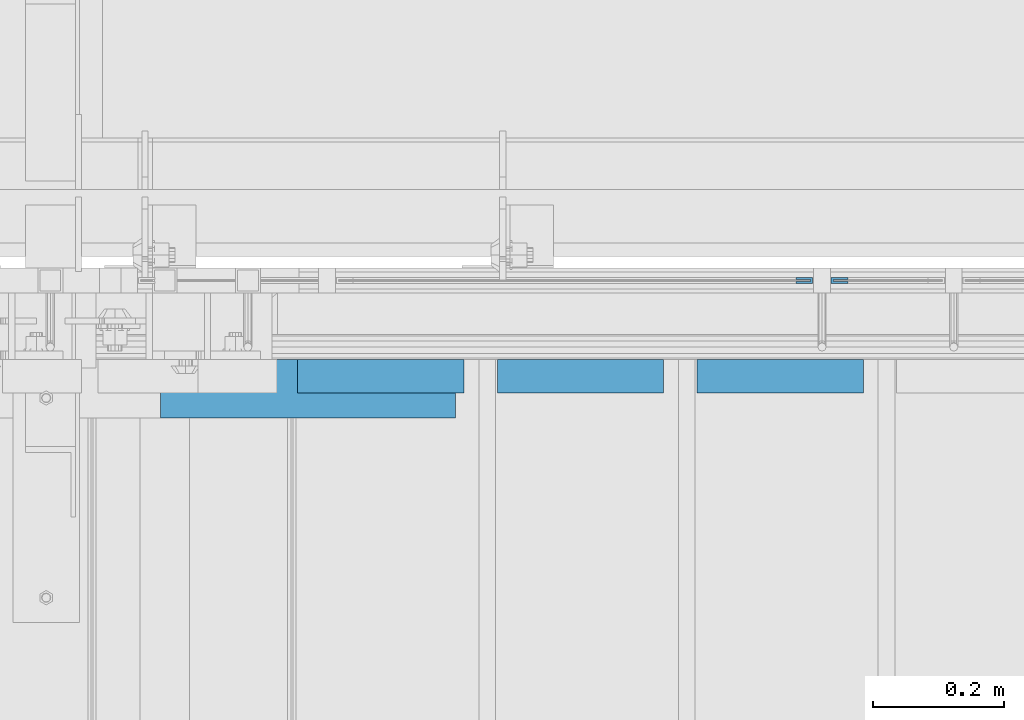
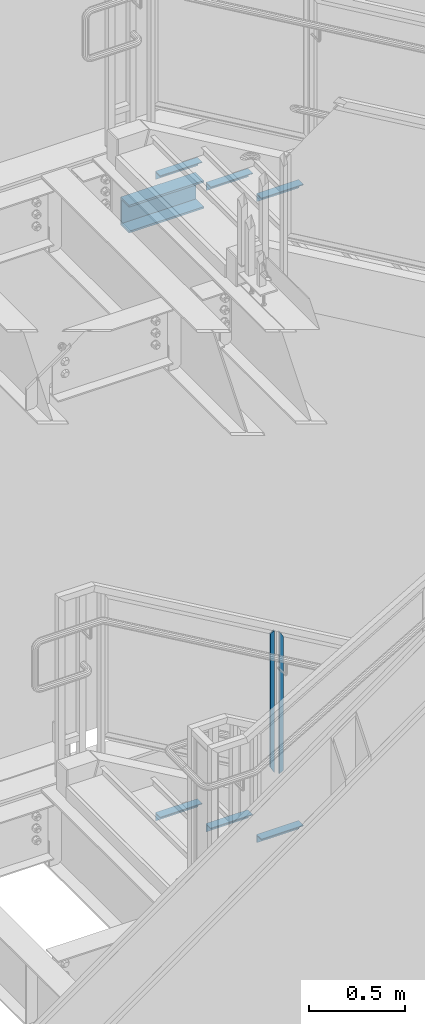
# One storey, part 937 of 1179: 9 beams, 3 elements without a shape of their own.
"""IFC2X3 building model written with IfcOpenShell, lengths in millimetres."""

from ifc_helpers import new_model, si_unit, frame, origin_with_axes, place, context, subcontext, project, spatial, faceted_brep, material, type_object, element, aggregate, save


model = new_model("IFC2X3")

# Units and contexts
model_context = context("Model", 3, precision=1e-05, world=origin_with_axes())
body_context = subcontext(model_context, "Body", "Model", "MODEL_VIEW")
ifc_project = project(units=[si_unit("LENGTHUNIT", "METRE", prefix="MILLI"), si_unit("AREAUNIT", "SQUARE_METRE"), si_unit("VOLUMEUNIT", "CUBIC_METRE"), si_unit("MASSUNIT", "GRAM", prefix="KILO"), si_unit("TIMEUNIT", "SECOND"), si_unit("PLANEANGLEUNIT", "RADIAN"), si_unit("SOLIDANGLEUNIT", "STERADIAN"), si_unit("THERMODYNAMICTEMPERATUREUNIT", "DEGREE_CELSIUS"), si_unit("LUMINOUSINTENSITYUNIT", "LUMEN")], contexts=[model_context])

# Site, building, storey
site_placement = place(None, origin_with_axes())
site = spatial("IfcSite", under=ifc_project, at=site_placement, CompositionType="ELEMENT")
building_placement = place(site_placement, origin_with_axes())
building = spatial("IfcBuilding", under=site, at=building_placement, Name="Undefined", CompositionType="ELEMENT")
storey_placement = place(building_placement, origin_with_axes())
storey = spatial("IfcBuildingStorey", under=building, at=storey_placement, Name="Undefined", CompositionType="ELEMENT", Elevation=0.0)

# Assembly, beams
assembly_1_placement = place(storey_placement, origin_with_axes())
assembly_1 = element("IfcElementAssembly", 1, at=assembly_1_placement, inside=storey, Name="GUARDRAIL", AssemblyPlace="NOTDEFINED", PredefinedType="RIGID_FRAME")
ifc_material_1 = material(Name="STEEL/BUY-OUT")
beam_type_1 = type_object("IfcBeamType", PredefinedType="NOTDEFINED")
beam_1_placement = place(assembly_1_placement, frame((20569.2374611471, 41062.2751647691, 4190.68543024958), z_axis=(0.0, 0.0, -1.0), x_axis=(1.0, 0.0, 0.0)))
beam_1 = element("IfcBeam", 2, at=beam_1_placement, type_object=beam_type_1, material=ifc_material_1, Name="U-EDGE", context=body_context, shape_type="Brep", body=[
    faceted_brep([(0.0, 1.58750000000146, 410.762302941614), (25.400000000016, 1.58750000000146, 454.819), (25.400000000016, 1.58750000000146, -454.819), (0.0, 1.58750000000146, -440.175144311391), (0.0, -1.58750000000146, 410.762302941614), (0.0, -1.58750000000146, -440.175144311391), (22.2250000000131, -1.58750000000146, 449.311912867583), (22.2250000000131, -1.58750000000146, -452.988518038564), (22.2250000000131, -4.76249999999709, 449.311912867583), (22.2250000000131, -4.76249999999709, -452.988518038564), (2.91038304567337e-11, -4.76249999999709, 410.762302941664), (2.91038304567337e-11, -4.76249999999709, -440.175144311408), (2.91038304567337e-11, -7.9375, 410.762302941664), (2.91038304567337e-11, -7.9375, -440.175144311408), (25.400000000016, -7.9375, 454.819), (25.400000000016, -7.9375, -454.819)], [[[0, 1, 2, 3]], [[4, 0, 3, 5]], [[6, 4, 5, 7]], [[8, 6, 7, 9]], [[10, 8, 9, 11]], [[12, 10, 11, 13]], [[14, 12, 13, 15]], [[11, 9, 7, 5, 3, 2, 15, 13]], [[1, 14, 15, 2]], [[0, 4, 6, 8, 10, 12, 14, 1]]]),
])
beam_2_placement = place(assembly_1_placement, frame((20648.3080706334, 41062.2751647691, 4174.31694368419), z_axis=(0.0, 0.0, -1.0), x_axis=(-1.0, 0.0, 0.0)))
beam_2 = element("IfcBeam", 3, at=beam_2_placement, type_object=beam_type_1, material=ifc_material_1, Name="U-EDGE", context=body_context, shape_type="Brep", body=[
    faceted_brep([(2.91038304567337e-11, 7.9375, 440.175302877862), (25.3999999999687, 7.9375, 454.819), (25.400000000016, 7.9375, -454.819), (2.91038304567337e-11, 7.9375, -410.76229705665), (2.91038304567337e-11, 4.76249999999709, 440.175302877862), (2.91038304567337e-11, 4.76249999999709, -410.76229705665), (22.2250000000131, 4.76249999999709, 452.988538277322), (22.2250000000131, 4.76249999999709, -449.311912132071), (22.2250000000131, 1.58750000000146, 452.988538277322), (22.2250000000131, 1.58750000000146, -449.311912132071), (0.0, 1.58750000000146, 440.175302877845), (0.0, 1.58750000000146, -410.7622970566), (0.0, -1.58750000000146, 440.175302877845), (0.0, -1.58750000000146, -410.7622970566), (25.3999999999687, -1.58750000000146, 454.819), (25.400000000016, -1.58750000000146, -454.819)], [[[0, 1, 2, 3]], [[4, 0, 3, 5]], [[6, 4, 5, 7]], [[8, 6, 7, 9]], [[10, 8, 9, 11]], [[12, 10, 11, 13]], [[14, 12, 13, 15]], [[11, 9, 7, 5, 3, 2, 15, 13]], [[1, 14, 15, 2]], [[0, 4, 6, 8, 10, 12, 14, 1]]]),
])
aggregate(assembly_1, [beam_1, beam_2])

assembly_2_placement = place(storey_placement, origin_with_axes())
assembly_2 = element("IfcElementAssembly", 4, at=assembly_2_placement, inside=storey, Name="STAIR", AssemblyPlace="NOTDEFINED", PredefinedType="RIGID_FRAME")
ifc_material_2 = material(Name="STEEL/A36")
beam_type_2 = type_object("IfcBeamType", Name="L2X2X3/16", PredefinedType="NOTDEFINED")
beam_3_placement = place(assembly_2_placement, frame((19808.4321735375, 40919.4000001337, 3803.71613283766), z_axis=(0.0, -1.0, 0.0), x_axis=(1.0, 0.0, 0.0)))
beam_3 = element("IfcBeam", 5, at=beam_3_placement, type_object=beam_type_2, material=ifc_material_2, Name="ANGLE", ObjectType="L2X2X3/16", context=body_context, shape_type="Brep", body=[
    faceted_brep([(0.0, 25.3999999999996, -25.4000000000015), (0.0, 25.3999999999996, 25.4000000000015), (254.0, 25.3999999999996, 25.4000000000001), (254.0, 25.3999999999996, -25.4000000000001), (0.0, 20.6374999999998, 25.4000000000015), (254.0, 20.6374999999998, 25.4000000000001), (0.0, 20.6374999999998, -20.6374999999971), (254.0, 20.6374999999998, -20.6374999999998), (0.0, -25.3999999999996, -20.6374999999971), (254.0, -25.3999999999996, -20.6374999999998), (0.0, -25.3999999999996, -25.4000000000015), (254.0, -25.3999999999996, -25.4000000000001)], [[[0, 1, 2, 3]], [[1, 4, 5, 2]], [[4, 6, 7, 5]], [[6, 8, 9, 7]], [[8, 10, 11, 9]], [[10, 0, 3, 11]], [[5, 7, 9, 11, 3, 2]], [[10, 8, 6, 4, 1, 0]]]),
])
beam_4_placement = place(assembly_2_placement, frame((20113.2321735301, 40919.4000001315, 3627.23904955395), z_axis=(0.0, -1.0, 0.0), x_axis=(1.0, 0.0, 0.0)))
beam_4 = element("IfcBeam", 6, at=beam_4_placement, type_object=beam_type_2, material=ifc_material_2, Name="ANGLE", ObjectType="L2X2X3/16", context=body_context, shape_type="Brep", body=[
    faceted_brep([(0.0, 25.3999999999996, -25.4000000000015), (0.0, 25.3999999999996, 25.4000000000015), (254.0, 25.3999999999996, 25.4000000000001), (254.0, 25.3999999999996, -25.4000000000001), (0.0, 20.6374999999998, 25.4000000000015), (254.0, 20.6374999999998, 25.4000000000001), (0.0, 20.6374999999998, -20.6374999999971), (254.0, 20.6374999999998, -20.6374999999998), (0.0, -25.3999999999996, -20.6374999999971), (254.0, -25.3999999999996, -20.6374999999998), (0.0, -25.3999999999996, -25.4000000000015), (254.0, -25.3999999999996, -25.4000000000001)], [[[0, 1, 2, 3]], [[1, 4, 5, 2]], [[4, 6, 7, 5]], [[6, 8, 9, 7]], [[8, 10, 11, 9]], [[10, 0, 3, 11]], [[5, 7, 9, 11, 3, 2]], [[10, 8, 6, 4, 1, 0]]]),
])
beam_5_placement = place(assembly_2_placement, frame((20418.0321735227, 40919.4000001293, 3450.76196627024), z_axis=(0.0, -1.0, 0.0), x_axis=(1.0, 0.0, 0.0)))
beam_5 = element("IfcBeam", 7, at=beam_5_placement, type_object=beam_type_2, material=ifc_material_2, Name="ANGLE", ObjectType="L2X2X3/16", context=body_context, shape_type="Brep", body=[
    faceted_brep([(0.0, 25.3999999999996, -25.4000000000015), (0.0, 25.3999999999996, 25.4000000000015), (254.0, 25.3999999999996, 25.4000000000001), (254.0, 25.3999999999996, -25.4000000000001), (0.0, 20.6374999999998, 25.4000000000015), (254.0, 20.6374999999998, 25.4000000000001), (0.0, 20.6374999999998, -20.6374999999971), (254.0, 20.6374999999998, -20.6374999999998), (0.0, -25.3999999999996, -20.6374999999971), (254.0, -25.3999999999996, -20.6374999999998), (0.0, -25.3999999999996, -25.4000000000015), (254.0, -25.3999999999996, -25.4000000000001)], [[[0, 1, 2, 3]], [[1, 4, 5, 2]], [[4, 6, 7, 5]], [[6, 8, 9, 7]], [[8, 10, 11, 9]], [[10, 0, 3, 11]], [[5, 7, 9, 11, 3, 2]], [[10, 8, 6, 4, 1, 0]]]),
])
aggregate(assembly_2, [beam_3, beam_4, beam_5])

assembly_3_placement = place(storey_placement, origin_with_axes())
assembly_3 = element("IfcElementAssembly", 8, at=assembly_3_placement, inside=storey, Name="STAIR", AssemblyPlace="NOTDEFINED", PredefinedType="RIGID_FRAME")
beam_6_placement = place(assembly_3_placement, frame((19808.4869692969, 40919.3999999982, 7890.47030000811), z_axis=(0.0, -1.0, 0.0), x_axis=(1.0, 0.0, 0.0)))
beam_6 = element("IfcBeam", 9, at=beam_6_placement, type_object=beam_type_2, material=ifc_material_2, Name="ANGLE", ObjectType="L2X2X3/16", context=body_context, shape_type="Brep", body=[
    faceted_brep([(0.0, 25.3999999999996, -25.4000000000015), (0.0, 25.3999999999996, 25.4000000000015), (254.0, 25.3999999999996, 25.4000000000001), (254.0, 25.3999999999996, -25.4000000000001), (0.0, 20.6374999999998, 25.4000000000015), (254.0, 20.6374999999998, 25.4000000000001), (0.0, 20.6374999999998, -20.6374999999971), (254.0, 20.6374999999998, -20.6374999999998), (0.0, -25.3999999999996, -20.6374999999971), (254.0, -25.3999999999996, -20.6374999999998), (0.0, -25.3999999999996, -25.4000000000015), (254.0, -25.3999999999996, -25.4000000000001)], [[[0, 1, 2, 3]], [[1, 4, 5, 2]], [[4, 6, 7, 5]], [[6, 8, 9, 7]], [[8, 10, 11, 9]], [[10, 0, 3, 11]], [[5, 7, 9, 11, 3, 2]], [[10, 8, 6, 4, 1, 0]]]),
])
beam_7_placement = place(assembly_3_placement, frame((20113.2869690449, 40919.3999999982, 7712.67030000811), z_axis=(0.0, -1.0, 0.0), x_axis=(1.0, 0.0, 0.0)))
beam_7 = element("IfcBeam", 10, at=beam_7_placement, type_object=beam_type_2, material=ifc_material_2, Name="ANGLE", ObjectType="L2X2X3/16", context=body_context, shape_type="Brep", body=[
    faceted_brep([(0.0, 25.3999999999996, -25.4000000000015), (0.0, 25.3999999999996, 25.4000000000015), (254.0, 25.3999999999996, 25.4000000000001), (254.0, 25.3999999999996, -25.4000000000001), (0.0, 20.6374999999998, 25.4000000000015), (254.0, 20.6374999999998, 25.4000000000001), (0.0, 20.6374999999998, -20.6374999999971), (254.0, 20.6374999999998, -20.6374999999998), (0.0, -25.3999999999996, -20.6374999999971), (254.0, -25.3999999999996, -20.6374999999998), (0.0, -25.3999999999996, -25.4000000000015), (254.0, -25.3999999999996, -25.4000000000001)], [[[0, 1, 2, 3]], [[1, 4, 5, 2]], [[4, 6, 7, 5]], [[6, 8, 9, 7]], [[8, 10, 11, 9]], [[10, 0, 3, 11]], [[5, 7, 9, 11, 3, 2]], [[10, 8, 6, 4, 1, 0]]]),
])
beam_8_placement = place(assembly_3_placement, frame((20418.0869687928, 40919.3999999982, 7534.87030000811), z_axis=(0.0, -1.0, 0.0), x_axis=(1.0, 0.0, 0.0)))
beam_8 = element("IfcBeam", 11, at=beam_8_placement, type_object=beam_type_2, material=ifc_material_2, Name="ANGLE", ObjectType="L2X2X3/16", context=body_context, shape_type="Brep", body=[
    faceted_brep([(0.0, 25.3999999999996, -25.4000000000015), (0.0, 25.3999999999996, 25.4000000000015), (254.0, 25.3999999999996, 25.4000000000001), (254.0, 25.3999999999996, -25.4000000000001), (0.0, 20.6374999999998, 25.4000000000015), (254.0, 20.6374999999998, 25.4000000000001), (0.0, 20.6374999999998, -20.6374999999971), (254.0, 20.6374999999998, -20.6374999999998), (0.0, -25.3999999999996, -20.6374999999971), (254.0, -25.3999999999996, -20.6374999999998), (0.0, -25.3999999999996, -25.4000000000015), (254.0, -25.3999999999996, -25.4000000000001)], [[[0, 1, 2, 3]], [[1, 4, 5, 2]], [[4, 6, 7, 5]], [[6, 8, 9, 7]], [[8, 10, 11, 9]], [[10, 0, 3, 11]], [[5, 7, 9, 11, 3, 2]], [[10, 8, 6, 4, 1, 0]]]),
])
beam_type_3 = type_object("IfcBeamType", Name="MC7X19.1", PredefinedType="NOTDEFINED")
beam_9_placement = place(assembly_3_placement, frame((19600.126308587, 40900.3500000048, 7735.8875), z_axis=(0.0, 0.0, 1.0), x_axis=(1.0, 0.0, 0.0)))
beam_9 = element("IfcBeam", 12, at=beam_9_placement, type_object=beam_type_3, material=ifc_material_2, Name="BEAM", ObjectType="MC7X19.1", context=body_context, shape_type="Brep", body=[
    faceted_brep([(-0.851308586949017, 44.4499999999971, -88.8999999999996), (-0.851308586949017, 44.4499999999971, 88.8999999999996), (449.289421374284, 44.4499999999971, 88.8999999999996), (449.289421374284, 44.4499999999971, -88.8999999999996), (-0.851308586949017, -44.4499999999971, 88.8999999999996), (449.289421374284, -44.4499999999971, 88.8999999999996), (-0.851308586949017, -44.4499999999971, 77.0845550000004), (449.289421374284, -44.4499999999971, 77.0845550000004), (-0.851308586949017, 34.9250000000029, 75.5049925000003), (449.289421374284, 34.9250000000029, 75.5049925000003), (-0.851308586949017, 34.9250000000029, -75.5049925000003), (449.289421374284, 34.9250000000029, -75.5049925000003), (-0.851308586949017, -44.4499999999971, -77.0845550000004), (449.289421374284, -44.4499999999971, -77.0845550000004), (-0.851308586949017, -44.4499999999971, -88.8999999999996), (449.289421374284, -44.4499999999971, -88.8999999999996)], [[[0, 1, 2, 3]], [[1, 4, 5, 2]], [[4, 6, 7, 5]], [[6, 8, 9, 7]], [[8, 10, 11, 9]], [[10, 12, 13, 11]], [[12, 14, 15, 13]], [[14, 0, 3, 15]], [[5, 7, 9, 11, 13, 15, 3, 2]], [[14, 12, 10, 8, 6, 4, 1, 0]]]),
])
aggregate(assembly_3, [beam_9, beam_6, beam_7, beam_8])

save(model, "model.ifc")
